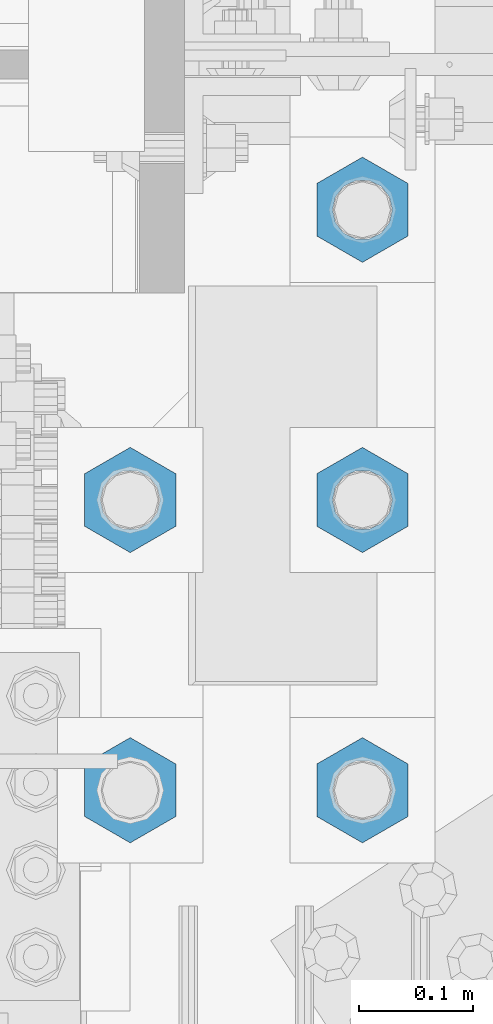
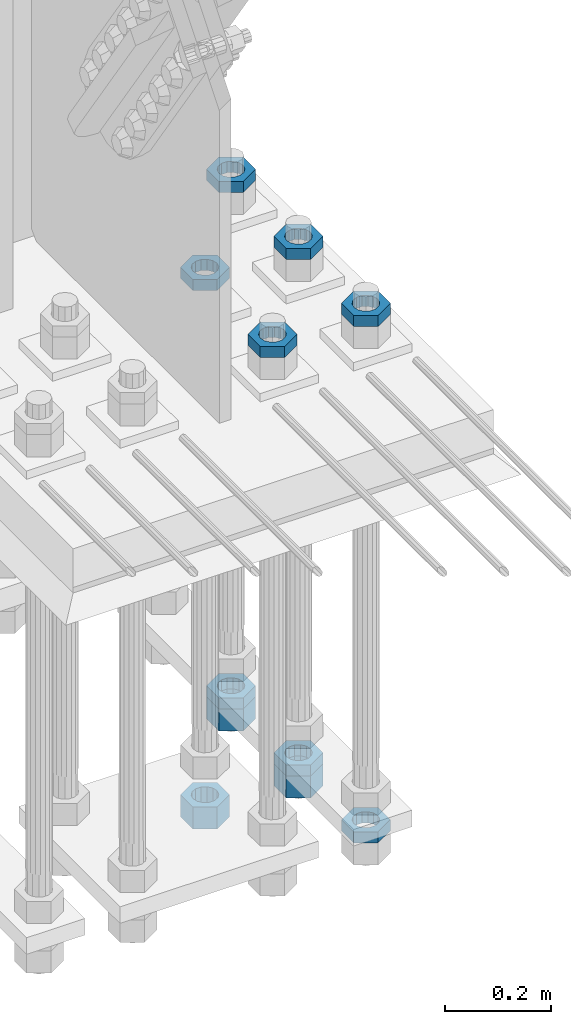
# One storey, part 2385 of 3843: 11 beams, 1 element without a shape of its own.
"""IFC2X3 building model written with IfcOpenShell, lengths in millimetres."""

from ifc_helpers import new_model, si_unit, frame, origin_with_axes, place, context, subcontext, project, spatial, faceted_brep, material, type_object, element, aggregate, save


model = new_model("IFC2X3")

# Units and contexts
model_context = context("Model", 3, precision=1e-05, world=origin_with_axes())
body_context = subcontext(model_context, "Body", "Model", "MODEL_VIEW")
ifc_project = project(units=[si_unit("LENGTHUNIT", "METRE", prefix="MILLI"), si_unit("AREAUNIT", "SQUARE_METRE"), si_unit("VOLUMEUNIT", "CUBIC_METRE"), si_unit("MASSUNIT", "GRAM", prefix="KILO"), si_unit("TIMEUNIT", "SECOND"), si_unit("PLANEANGLEUNIT", "RADIAN"), si_unit("SOLIDANGLEUNIT", "STERADIAN"), si_unit("THERMODYNAMICTEMPERATUREUNIT", "DEGREE_CELSIUS"), si_unit("LUMINOUSINTENSITYUNIT", "LUMEN")], contexts=[model_context])

# Site, building, storey
site_placement = place(None, origin_with_axes())
site = spatial("IfcSite", under=ifc_project, at=site_placement, CompositionType="ELEMENT")
building_placement = place(site_placement, origin_with_axes())
building = spatial("IfcBuilding", under=site, at=building_placement, Name="Undefined", CompositionType="ELEMENT")
storey_placement = place(building_placement, origin_with_axes())
storey = spatial("IfcBuildingStorey", under=building, at=storey_placement, Name="Undefined", CompositionType="ELEMENT", Elevation=0.0)

# Assembly, beams
assembly_placement = place(storey_placement, origin_with_axes())
assembly = element("IfcElementAssembly", 1, at=assembly_placement, inside=storey, Name="TEMPLATE", AssemblyPlace="NOTDEFINED", PredefinedType="RIGID_FRAME")
ifc_material = material(Name="STEEL/A572-50")
beam_type_1 = type_object("IfcBeamType", Name="2_HALF_NUT", PredefinedType="NOTDEFINED")
beam_1_placement = place(assembly_placement, frame((36931.6, 74993.5, 29070.3), z_axis=(1.0, 0.0, 0.0), x_axis=(0.0, 0.0, -1.0)))
beam_1 = element("IfcBeam", 2, at=beam_1_placement, type_object=beam_type_1, material=ifc_material, Name="NUT", ObjectType="2_HALF_NUT", context=body_context, shape_type="Brep", body=[
    faceted_brep([(0.0, -46.0369987487793, 0.0), (0.0, -23.0184993743896, -39.869213104248), (25.4000000000015, -23.0184993743896, -39.869213104248), (25.4000000000015, -46.0369987487793, 0.0), (0.0, 23.0184993743896, -39.869213104248), (25.4000000000015, 23.0184993743896, -39.869213104248), (0.0, 46.0369987487793, 0.0), (25.4000000000015, 46.0369987487793, 0.0), (0.0, 23.0184993743896, 39.869213104248), (25.4000000000015, 23.0184993743896, 39.869213104248), (0.0, -23.0184993743896, 39.869213104248), (25.4000000000015, -23.0184993743896, 39.869213104248), (0.0, 0.0, 26.1940002441406), (0.0, 11.3650617044477, 23.5999013092805), (25.4000000000015, 11.3650617044477, 23.5999013092805), (25.4000000000015, 0.0, 26.1940002441406), (0.0, 20.4791109456419, 16.3316083006721), (25.4000000000015, 20.4791109456419, 16.3316083006721), (0.0, 25.5370200498292, 5.82867859874386), (25.4000000000015, 25.5370200498292, 5.82867859874386), (0.0, 25.5370200498292, -5.82867859874386), (25.4000000000015, 25.5370200498292, -5.82867859874386), (0.0, 20.4791109456419, -16.3316083006721), (25.4000000000015, 20.4791109456419, -16.3316083006721), (0.0, 11.3650617044477, -23.5999013092805), (25.4000000000015, 11.3650617044477, -23.5999013092805), (0.0, 0.0, -26.1940002441406), (25.4000000000015, 0.0, -26.1940002441406), (0.0, -11.3650617044477, -23.5999013092805), (25.4000000000015, -11.3650617044477, -23.5999013092805), (0.0, -20.4791109456419, -16.3316083006721), (25.4000000000015, -20.4791109456419, -16.3316083006721), (0.0, -25.5370200498292, -5.82867859874386), (25.4000000000015, -25.5370200498292, -5.82867859874386), (0.0, -25.5370200498292, 5.82867859874386), (25.4000000000015, -25.5370200498292, 5.82867859874386), (0.0, -20.4791109456419, 16.3316083006721), (25.4000000000015, -20.4791109456419, 16.3316083006721), (0.0, -11.3650617044477, 23.5999013092805), (25.4000000000015, -11.3650617044477, 23.5999013092805)], [[[0, 1, 2, 3]], [[1, 4, 5, 2]], [[4, 6, 7, 5]], [[6, 8, 9, 7]], [[8, 10, 11, 9]], [[10, 0, 3, 11]], [[12, 13, 14, 15]], [[13, 16, 17, 14]], [[16, 18, 19, 17]], [[18, 20, 21, 19]], [[20, 22, 23, 21]], [[22, 24, 25, 23]], [[24, 26, 27, 25]], [[26, 28, 29, 27]], [[28, 30, 31, 29]], [[30, 32, 33, 31]], [[32, 34, 35, 33]], [[34, 36, 37, 35]], [[36, 38, 39, 37]], [[38, 12, 15, 39]], [[5, 7, 9, 11, 3, 2], [17, 19, 21, 23, 25, 27, 29, 31, 33, 35, 37, 39, 15, 14]], [[10, 8, 6, 4, 1, 0], [38, 36, 34, 32, 30, 28, 26, 24, 22, 20, 18, 16, 13, 12]]]),
])
beam_2_placement = place(assembly_placement, frame((36931.6, 75247.5, 29070.3), z_axis=(1.0, 0.0, 0.0), x_axis=(0.0, 0.0, -1.0)))
beam_2 = element("IfcBeam", 3, at=beam_2_placement, type_object=beam_type_1, material=ifc_material, Name="NUT", ObjectType="2_HALF_NUT", context=body_context, shape_type="Brep", body=[
    faceted_brep([(0.0, -46.0369987487793, 0.0), (0.0, -23.0184993743896, -39.869213104248), (25.4000000000015, -23.0184993743896, -39.869213104248), (25.4000000000015, -46.0369987487793, 0.0), (0.0, 23.0184993743896, -39.869213104248), (25.4000000000015, 23.0184993743896, -39.869213104248), (0.0, 46.0369987487793, 0.0), (25.4000000000015, 46.0369987487793, 0.0), (0.0, 23.0184993743896, 39.869213104248), (25.4000000000015, 23.0184993743896, 39.869213104248), (0.0, -23.0184993743896, 39.869213104248), (25.4000000000015, -23.0184993743896, 39.869213104248), (0.0, 0.0, 26.1940002441406), (0.0, 11.3650617044477, 23.5999013092805), (25.4000000000015, 11.3650617044477, 23.5999013092805), (25.4000000000015, 0.0, 26.1940002441406), (0.0, 20.4791109456419, 16.3316083006721), (25.4000000000015, 20.4791109456419, 16.3316083006721), (0.0, 25.5370200498292, 5.82867859874386), (25.4000000000015, 25.5370200498292, 5.82867859874386), (0.0, 25.5370200498292, -5.82867859874386), (25.4000000000015, 25.5370200498292, -5.82867859874386), (0.0, 20.4791109456419, -16.3316083006721), (25.4000000000015, 20.4791109456419, -16.3316083006721), (0.0, 11.3650617044477, -23.5999013092805), (25.4000000000015, 11.3650617044477, -23.5999013092805), (0.0, 0.0, -26.1940002441406), (25.4000000000015, 0.0, -26.1940002441406), (0.0, -11.3650617044477, -23.5999013092805), (25.4000000000015, -11.3650617044477, -23.5999013092805), (0.0, -20.4791109456419, -16.3316083006721), (25.4000000000015, -20.4791109456419, -16.3316083006721), (0.0, -25.5370200498292, -5.82867859874386), (25.4000000000015, -25.5370200498292, -5.82867859874386), (0.0, -25.5370200498292, 5.82867859874386), (25.4000000000015, -25.5370200498292, 5.82867859874386), (0.0, -20.4791109456419, 16.3316083006721), (25.4000000000015, -20.4791109456419, 16.3316083006721), (0.0, -11.3650617044477, 23.5999013092805), (25.4000000000015, -11.3650617044477, 23.5999013092805)], [[[0, 1, 2, 3]], [[1, 4, 5, 2]], [[4, 6, 7, 5]], [[6, 8, 9, 7]], [[8, 10, 11, 9]], [[10, 0, 3, 11]], [[12, 13, 14, 15]], [[13, 16, 17, 14]], [[16, 18, 19, 17]], [[18, 20, 21, 19]], [[20, 22, 23, 21]], [[22, 24, 25, 23]], [[24, 26, 27, 25]], [[26, 28, 29, 27]], [[28, 30, 31, 29]], [[30, 32, 33, 31]], [[32, 34, 35, 33]], [[34, 36, 37, 35]], [[36, 38, 39, 37]], [[38, 12, 15, 39]], [[5, 7, 9, 11, 3, 2], [17, 19, 21, 23, 25, 27, 29, 31, 33, 35, 37, 39, 15, 14]], [[10, 8, 6, 4, 1, 0], [38, 36, 34, 32, 30, 28, 26, 24, 22, 20, 18, 16, 13, 12]]]),
])
beam_3_placement = place(assembly_placement, frame((36931.6, 75501.5, 29070.3), z_axis=(-1.0, 0.0, 0.0), x_axis=(0.0, 0.0, -1.0)))
beam_3 = element("IfcBeam", 4, at=beam_3_placement, type_object=beam_type_1, material=ifc_material, Name="NUT", ObjectType="2_HALF_NUT", context=body_context, shape_type="Brep", body=[
    faceted_brep([(0.0, -46.0369987487793, 0.0), (0.0, -23.0184993743896, -39.869213104248), (25.4000000000015, -23.0184993743896, -39.869213104248), (25.4000000000015, -46.0369987487793, 0.0), (0.0, 23.0184993743896, -39.869213104248), (25.4000000000015, 23.0184993743896, -39.869213104248), (0.0, 46.0369987487793, 0.0), (25.4000000000015, 46.0369987487793, 0.0), (0.0, 23.0184993743896, 39.869213104248), (25.4000000000015, 23.0184993743896, 39.869213104248), (0.0, -23.0184993743896, 39.869213104248), (25.4000000000015, -23.0184993743896, 39.869213104248), (0.0, 0.0, 26.1940002441406), (0.0, 11.3650617044477, 23.5999013092805), (25.4000000000015, 11.3650617044477, 23.5999013092805), (25.4000000000015, 0.0, 26.1940002441406), (0.0, 20.4791109456419, 16.3316083006721), (25.4000000000015, 20.4791109456419, 16.3316083006721), (0.0, 25.5370200498292, 5.82867859874386), (25.4000000000015, 25.5370200498292, 5.82867859874386), (0.0, 25.5370200498292, -5.82867859874386), (25.4000000000015, 25.5370200498292, -5.82867859874386), (0.0, 20.4791109456419, -16.3316083006721), (25.4000000000015, 20.4791109456419, -16.3316083006721), (0.0, 11.3650617044477, -23.5999013092805), (25.4000000000015, 11.3650617044477, -23.5999013092805), (0.0, 0.0, -26.1940002441406), (25.4000000000015, 0.0, -26.1940002441406), (0.0, -11.3650617044477, -23.5999013092805), (25.4000000000015, -11.3650617044477, -23.5999013092805), (0.0, -20.4791109456419, -16.3316083006721), (25.4000000000015, -20.4791109456419, -16.3316083006721), (0.0, -25.5370200498292, -5.82867859874386), (25.4000000000015, -25.5370200498292, -5.82867859874386), (0.0, -25.5370200498292, 5.82867859874386), (25.4000000000015, -25.5370200498292, 5.82867859874386), (0.0, -20.4791109456419, 16.3316083006721), (25.4000000000015, -20.4791109456419, 16.3316083006721), (0.0, -11.3650617044477, 23.5999013092805), (25.4000000000015, -11.3650617044477, 23.5999013092805)], [[[0, 1, 2, 3]], [[1, 4, 5, 2]], [[4, 6, 7, 5]], [[6, 8, 9, 7]], [[8, 10, 11, 9]], [[10, 0, 3, 11]], [[12, 13, 14, 15]], [[13, 16, 17, 14]], [[16, 18, 19, 17]], [[18, 20, 21, 19]], [[20, 22, 23, 21]], [[22, 24, 25, 23]], [[24, 26, 27, 25]], [[26, 28, 29, 27]], [[28, 30, 31, 29]], [[30, 32, 33, 31]], [[32, 34, 35, 33]], [[34, 36, 37, 35]], [[36, 38, 39, 37]], [[38, 12, 15, 39]], [[5, 7, 9, 11, 3, 2], [17, 19, 21, 23, 25, 27, 29, 31, 33, 35, 37, 39, 15, 14]], [[10, 8, 6, 4, 1, 0], [38, 36, 34, 32, 30, 28, 26, 24, 22, 20, 18, 16, 13, 12]]]),
])
beam_4_placement = place(assembly_placement, frame((36728.4, 75247.5, 30257.75), z_axis=(-1.0, 0.0, 0.0), x_axis=(0.0, 0.0, -1.0)))
beam_4 = element("IfcBeam", 5, at=beam_4_placement, type_object=beam_type_1, material=ifc_material, Name="NUT", ObjectType="2_HALF_NUT", context=body_context, shape_type="Brep", body=[
    faceted_brep([(0.0, -46.0369987487793, 0.0), (0.0, -23.0184993743896, -39.869213104248), (25.4000000000015, -23.0184993743896, -39.869213104248), (25.4000000000015, -46.0369987487793, 0.0), (0.0, 23.0184993743896, -39.869213104248), (25.4000000000015, 23.0184993743896, -39.869213104248), (0.0, 46.0369987487793, 0.0), (25.4000000000015, 46.0369987487793, 0.0), (0.0, 23.0184993743896, 39.869213104248), (25.4000000000015, 23.0184993743896, 39.869213104248), (0.0, -23.0184993743896, 39.869213104248), (25.4000000000015, -23.0184993743896, 39.869213104248), (0.0, 0.0, 26.1940002441406), (0.0, 11.3650617044477, 23.5999013092805), (25.4000000000015, 11.3650617044477, 23.5999013092805), (25.4000000000015, 0.0, 26.1940002441406), (0.0, 20.4791109456419, 16.3316083006721), (25.4000000000015, 20.4791109456419, 16.3316083006721), (0.0, 25.5370200498292, 5.82867859874386), (25.4000000000015, 25.5370200498292, 5.82867859874386), (0.0, 25.5370200498292, -5.82867859874386), (25.4000000000015, 25.5370200498292, -5.82867859874386), (0.0, 20.4791109456419, -16.3316083006721), (25.4000000000015, 20.4791109456419, -16.3316083006721), (0.0, 11.3650617044477, -23.5999013092805), (25.4000000000015, 11.3650617044477, -23.5999013092805), (0.0, 0.0, -26.1940002441406), (25.4000000000015, 0.0, -26.1940002441406), (0.0, -11.3650617044477, -23.5999013092805), (25.4000000000015, -11.3650617044477, -23.5999013092805), (0.0, -20.4791109456419, -16.3316083006721), (25.4000000000015, -20.4791109456419, -16.3316083006721), (0.0, -25.5370200498292, -5.82867859874386), (25.4000000000015, -25.5370200498292, -5.82867859874386), (0.0, -25.5370200498292, 5.82867859874386), (25.4000000000015, -25.5370200498292, 5.82867859874386), (0.0, -20.4791109456419, 16.3316083006721), (25.4000000000015, -20.4791109456419, 16.3316083006721), (0.0, -11.3650617044477, 23.5999013092805), (25.4000000000015, -11.3650617044477, 23.5999013092805)], [[[0, 1, 2, 3]], [[1, 4, 5, 2]], [[4, 6, 7, 5]], [[6, 8, 9, 7]], [[8, 10, 11, 9]], [[10, 0, 3, 11]], [[12, 13, 14, 15]], [[13, 16, 17, 14]], [[16, 18, 19, 17]], [[18, 20, 21, 19]], [[20, 22, 23, 21]], [[22, 24, 25, 23]], [[24, 26, 27, 25]], [[26, 28, 29, 27]], [[28, 30, 31, 29]], [[30, 32, 33, 31]], [[32, 34, 35, 33]], [[34, 36, 37, 35]], [[36, 38, 39, 37]], [[38, 12, 15, 39]], [[5, 7, 9, 11, 3, 2], [17, 19, 21, 23, 25, 27, 29, 31, 33, 35, 37, 39, 15, 14]], [[10, 8, 6, 4, 1, 0], [38, 36, 34, 32, 30, 28, 26, 24, 22, 20, 18, 16, 13, 12]]]),
])
beam_5_placement = place(assembly_placement, frame((36728.4, 74993.5, 30257.75), z_axis=(-1.0, 0.0, 0.0), x_axis=(0.0, 0.0, -1.0)))
beam_5 = element("IfcBeam", 6, at=beam_5_placement, type_object=beam_type_1, material=ifc_material, Name="NUT", ObjectType="2_HALF_NUT", context=body_context, shape_type="Brep", body=[
    faceted_brep([(0.0, -46.0369987487793, 0.0), (0.0, -23.0184993743896, -39.869213104248), (25.4000000000015, -23.0184993743896, -39.869213104248), (25.4000000000015, -46.0369987487793, 0.0), (0.0, 23.0184993743896, -39.869213104248), (25.4000000000015, 23.0184993743896, -39.869213104248), (0.0, 46.0369987487793, 0.0), (25.4000000000015, 46.0369987487793, 0.0), (0.0, 23.0184993743896, 39.869213104248), (25.4000000000015, 23.0184993743896, 39.869213104248), (0.0, -23.0184993743896, 39.869213104248), (25.4000000000015, -23.0184993743896, 39.869213104248), (0.0, 0.0, 26.1940002441406), (0.0, 11.3650617044477, 23.5999013092805), (25.4000000000015, 11.3650617044477, 23.5999013092805), (25.4000000000015, 0.0, 26.1940002441406), (0.0, 20.4791109456419, 16.3316083006721), (25.4000000000015, 20.4791109456419, 16.3316083006721), (0.0, 25.5370200498292, 5.82867859874386), (25.4000000000015, 25.5370200498292, 5.82867859874386), (0.0, 25.5370200498292, -5.82867859874386), (25.4000000000015, 25.5370200498292, -5.82867859874386), (0.0, 20.4791109456419, -16.3316083006721), (25.4000000000015, 20.4791109456419, -16.3316083006721), (0.0, 11.3650617044477, -23.5999013092805), (25.4000000000015, 11.3650617044477, -23.5999013092805), (0.0, 0.0, -26.1940002441406), (25.4000000000015, 0.0, -26.1940002441406), (0.0, -11.3650617044477, -23.5999013092805), (25.4000000000015, -11.3650617044477, -23.5999013092805), (0.0, -20.4791109456419, -16.3316083006721), (25.4000000000015, -20.4791109456419, -16.3316083006721), (0.0, -25.5370200498292, -5.82867859874386), (25.4000000000015, -25.5370200498292, -5.82867859874386), (0.0, -25.5370200498292, 5.82867859874386), (25.4000000000015, -25.5370200498292, 5.82867859874386), (0.0, -20.4791109456419, 16.3316083006721), (25.4000000000015, -20.4791109456419, 16.3316083006721), (0.0, -11.3650617044477, 23.5999013092805), (25.4000000000015, -11.3650617044477, 23.5999013092805)], [[[0, 1, 2, 3]], [[1, 4, 5, 2]], [[4, 6, 7, 5]], [[6, 8, 9, 7]], [[8, 10, 11, 9]], [[10, 0, 3, 11]], [[12, 13, 14, 15]], [[13, 16, 17, 14]], [[16, 18, 19, 17]], [[18, 20, 21, 19]], [[20, 22, 23, 21]], [[22, 24, 25, 23]], [[24, 26, 27, 25]], [[26, 28, 29, 27]], [[28, 30, 31, 29]], [[30, 32, 33, 31]], [[32, 34, 35, 33]], [[34, 36, 37, 35]], [[36, 38, 39, 37]], [[38, 12, 15, 39]], [[5, 7, 9, 11, 3, 2], [17, 19, 21, 23, 25, 27, 29, 31, 33, 35, 37, 39, 15, 14]], [[10, 8, 6, 4, 1, 0], [38, 36, 34, 32, 30, 28, 26, 24, 22, 20, 18, 16, 13, 12]]]),
])
beam_6_placement = place(assembly_placement, frame((36931.6, 75501.5, 30257.75), z_axis=(1.0, 0.0, 0.0), x_axis=(0.0, 0.0, -1.0)))
beam_6 = element("IfcBeam", 7, at=beam_6_placement, type_object=beam_type_1, material=ifc_material, Name="NUT", ObjectType="2_HALF_NUT", context=body_context, shape_type="Brep", body=[
    faceted_brep([(0.0, -46.0369987487793, 0.0), (0.0, -23.0184993743896, -39.869213104248), (25.4000000000015, -23.0184993743896, -39.869213104248), (25.4000000000015, -46.0369987487793, 0.0), (0.0, 23.0184993743896, -39.869213104248), (25.4000000000015, 23.0184993743896, -39.869213104248), (0.0, 46.0369987487793, 0.0), (25.4000000000015, 46.0369987487793, 0.0), (0.0, 23.0184993743896, 39.869213104248), (25.4000000000015, 23.0184993743896, 39.869213104248), (0.0, -23.0184993743896, 39.869213104248), (25.4000000000015, -23.0184993743896, 39.869213104248), (0.0, 0.0, 26.1940002441406), (0.0, 11.3650617044477, 23.5999013092805), (25.4000000000015, 11.3650617044477, 23.5999013092805), (25.4000000000015, 0.0, 26.1940002441406), (0.0, 20.4791109456419, 16.3316083006721), (25.4000000000015, 20.4791109456419, 16.3316083006721), (0.0, 25.5370200498292, 5.82867859874386), (25.4000000000015, 25.5370200498292, 5.82867859874386), (0.0, 25.5370200498292, -5.82867859874386), (25.4000000000015, 25.5370200498292, -5.82867859874386), (0.0, 20.4791109456419, -16.3316083006721), (25.4000000000015, 20.4791109456419, -16.3316083006721), (0.0, 11.3650617044477, -23.5999013092805), (25.4000000000015, 11.3650617044477, -23.5999013092805), (0.0, 0.0, -26.1940002441406), (25.4000000000015, 0.0, -26.1940002441406), (0.0, -11.3650617044477, -23.5999013092805), (25.4000000000015, -11.3650617044477, -23.5999013092805), (0.0, -20.4791109456419, -16.3316083006721), (25.4000000000015, -20.4791109456419, -16.3316083006721), (0.0, -25.5370200498292, -5.82867859874386), (25.4000000000015, -25.5370200498292, -5.82867859874386), (0.0, -25.5370200498292, 5.82867859874386), (25.4000000000015, -25.5370200498292, 5.82867859874386), (0.0, -20.4791109456419, 16.3316083006721), (25.4000000000015, -20.4791109456419, 16.3316083006721), (0.0, -11.3650617044477, 23.5999013092805), (25.4000000000015, -11.3650617044477, 23.5999013092805)], [[[0, 1, 2, 3]], [[1, 4, 5, 2]], [[4, 6, 7, 5]], [[6, 8, 9, 7]], [[8, 10, 11, 9]], [[10, 0, 3, 11]], [[12, 13, 14, 15]], [[13, 16, 17, 14]], [[16, 18, 19, 17]], [[18, 20, 21, 19]], [[20, 22, 23, 21]], [[22, 24, 25, 23]], [[24, 26, 27, 25]], [[26, 28, 29, 27]], [[28, 30, 31, 29]], [[30, 32, 33, 31]], [[32, 34, 35, 33]], [[34, 36, 37, 35]], [[36, 38, 39, 37]], [[38, 12, 15, 39]], [[5, 7, 9, 11, 3, 2], [17, 19, 21, 23, 25, 27, 29, 31, 33, 35, 37, 39, 15, 14]], [[10, 8, 6, 4, 1, 0], [38, 36, 34, 32, 30, 28, 26, 24, 22, 20, 18, 16, 13, 12]]]),
])
beam_7_placement = place(assembly_placement, frame((36931.6, 75247.5, 30257.75), z_axis=(-1.0, 0.0, 0.0), x_axis=(0.0, 0.0, -1.0)))
beam_7 = element("IfcBeam", 8, at=beam_7_placement, type_object=beam_type_1, material=ifc_material, Name="NUT", ObjectType="2_HALF_NUT", context=body_context, shape_type="Brep", body=[
    faceted_brep([(0.0, -46.0369987487793, 0.0), (0.0, -23.0184993743896, -39.869213104248), (25.4000000000015, -23.0184993743896, -39.869213104248), (25.4000000000015, -46.0369987487793, 0.0), (0.0, 23.0184993743896, -39.869213104248), (25.4000000000015, 23.0184993743896, -39.869213104248), (0.0, 46.0369987487793, 0.0), (25.4000000000015, 46.0369987487793, 0.0), (0.0, 23.0184993743896, 39.869213104248), (25.4000000000015, 23.0184993743896, 39.869213104248), (0.0, -23.0184993743896, 39.869213104248), (25.4000000000015, -23.0184993743896, 39.869213104248), (0.0, 0.0, 26.1940002441406), (0.0, 11.3650617044477, 23.5999013092805), (25.4000000000015, 11.3650617044477, 23.5999013092805), (25.4000000000015, 0.0, 26.1940002441406), (0.0, 20.4791109456419, 16.3316083006721), (25.4000000000015, 20.4791109456419, 16.3316083006721), (0.0, 25.5370200498292, 5.82867859874386), (25.4000000000015, 25.5370200498292, 5.82867859874386), (0.0, 25.5370200498292, -5.82867859874386), (25.4000000000015, 25.5370200498292, -5.82867859874386), (0.0, 20.4791109456419, -16.3316083006721), (25.4000000000015, 20.4791109456419, -16.3316083006721), (0.0, 11.3650617044477, -23.5999013092805), (25.4000000000015, 11.3650617044477, -23.5999013092805), (0.0, 0.0, -26.1940002441406), (25.4000000000015, 0.0, -26.1940002441406), (0.0, -11.3650617044477, -23.5999013092805), (25.4000000000015, -11.3650617044477, -23.5999013092805), (0.0, -20.4791109456419, -16.3316083006721), (25.4000000000015, -20.4791109456419, -16.3316083006721), (0.0, -25.5370200498292, -5.82867859874386), (25.4000000000015, -25.5370200498292, -5.82867859874386), (0.0, -25.5370200498292, 5.82867859874386), (25.4000000000015, -25.5370200498292, 5.82867859874386), (0.0, -20.4791109456419, 16.3316083006721), (25.4000000000015, -20.4791109456419, 16.3316083006721), (0.0, -11.3650617044477, 23.5999013092805), (25.4000000000015, -11.3650617044477, 23.5999013092805)], [[[0, 1, 2, 3]], [[1, 4, 5, 2]], [[4, 6, 7, 5]], [[6, 8, 9, 7]], [[8, 10, 11, 9]], [[10, 0, 3, 11]], [[12, 13, 14, 15]], [[13, 16, 17, 14]], [[16, 18, 19, 17]], [[18, 20, 21, 19]], [[20, 22, 23, 21]], [[22, 24, 25, 23]], [[24, 26, 27, 25]], [[26, 28, 29, 27]], [[28, 30, 31, 29]], [[30, 32, 33, 31]], [[32, 34, 35, 33]], [[34, 36, 37, 35]], [[36, 38, 39, 37]], [[38, 12, 15, 39]], [[5, 7, 9, 11, 3, 2], [17, 19, 21, 23, 25, 27, 29, 31, 33, 35, 37, 39, 15, 14]], [[10, 8, 6, 4, 1, 0], [38, 36, 34, 32, 30, 28, 26, 24, 22, 20, 18, 16, 13, 12]]]),
])
beam_8_placement = place(assembly_placement, frame((36931.6, 74993.5, 30257.75), z_axis=(-1.0, 0.0, 0.0), x_axis=(0.0, 0.0, -1.0)))
beam_8 = element("IfcBeam", 9, at=beam_8_placement, type_object=beam_type_1, material=ifc_material, Name="NUT", ObjectType="2_HALF_NUT", context=body_context, shape_type="Brep", body=[
    faceted_brep([(0.0, -46.0369987487793, 0.0), (0.0, -23.0184993743896, -39.869213104248), (25.4000000000015, -23.0184993743896, -39.869213104248), (25.4000000000015, -46.0369987487793, 0.0), (0.0, 23.0184993743896, -39.869213104248), (25.4000000000015, 23.0184993743896, -39.869213104248), (0.0, 46.0369987487793, 0.0), (25.4000000000015, 46.0369987487793, 0.0), (0.0, 23.0184993743896, 39.869213104248), (25.4000000000015, 23.0184993743896, 39.869213104248), (0.0, -23.0184993743896, 39.869213104248), (25.4000000000015, -23.0184993743896, 39.869213104248), (0.0, 0.0, 26.1940002441406), (0.0, 11.3650617044477, 23.5999013092805), (25.4000000000015, 11.3650617044477, 23.5999013092805), (25.4000000000015, 0.0, 26.1940002441406), (0.0, 20.4791109456419, 16.3316083006721), (25.4000000000015, 20.4791109456419, 16.3316083006721), (0.0, 25.5370200498292, 5.82867859874386), (25.4000000000015, 25.5370200498292, 5.82867859874386), (0.0, 25.5370200498292, -5.82867859874386), (25.4000000000015, 25.5370200498292, -5.82867859874386), (0.0, 20.4791109456419, -16.3316083006721), (25.4000000000015, 20.4791109456419, -16.3316083006721), (0.0, 11.3650617044477, -23.5999013092805), (25.4000000000015, 11.3650617044477, -23.5999013092805), (0.0, 0.0, -26.1940002441406), (25.4000000000015, 0.0, -26.1940002441406), (0.0, -11.3650617044477, -23.5999013092805), (25.4000000000015, -11.3650617044477, -23.5999013092805), (0.0, -20.4791109456419, -16.3316083006721), (25.4000000000015, -20.4791109456419, -16.3316083006721), (0.0, -25.5370200498292, -5.82867859874386), (25.4000000000015, -25.5370200498292, -5.82867859874386), (0.0, -25.5370200498292, 5.82867859874386), (25.4000000000015, -25.5370200498292, 5.82867859874386), (0.0, -20.4791109456419, 16.3316083006721), (25.4000000000015, -20.4791109456419, 16.3316083006721), (0.0, -11.3650617044477, 23.5999013092805), (25.4000000000015, -11.3650617044477, 23.5999013092805)], [[[0, 1, 2, 3]], [[1, 4, 5, 2]], [[4, 6, 7, 5]], [[6, 8, 9, 7]], [[8, 10, 11, 9]], [[10, 0, 3, 11]], [[12, 13, 14, 15]], [[13, 16, 17, 14]], [[16, 18, 19, 17]], [[18, 20, 21, 19]], [[20, 22, 23, 21]], [[22, 24, 25, 23]], [[24, 26, 27, 25]], [[26, 28, 29, 27]], [[28, 30, 31, 29]], [[30, 32, 33, 31]], [[32, 34, 35, 33]], [[34, 36, 37, 35]], [[36, 38, 39, 37]], [[38, 12, 15, 39]], [[5, 7, 9, 11, 3, 2], [17, 19, 21, 23, 25, 27, 29, 31, 33, 35, 37, 39, 15, 14]], [[10, 8, 6, 4, 1, 0], [38, 36, 34, 32, 30, 28, 26, 24, 22, 20, 18, 16, 13, 12]]]),
])
beam_type_2 = type_object("IfcBeamType", Name="2_HEAVY_HEX_NUT", PredefinedType="NOTDEFINED")
beam_9_placement = place(assembly_placement, frame((36931.6, 75247.5, 29044.9), z_axis=(1.0, 0.0, 0.0), x_axis=(0.0, 0.0, -1.0)))
beam_9 = element("IfcBeam", 10, at=beam_9_placement, type_object=beam_type_2, material=ifc_material, Name="NUT", ObjectType="2_HEAVY_HEX_NUT", context=body_context, shape_type="Brep", body=[
    faceted_brep([(0.0, -46.0369987487793, 0.0), (0.0, -23.0184993743896, -39.869213104248), (50.7999999999993, -23.0184993743896, -39.869213104248), (50.7999999999993, -46.0369987487793, 0.0), (0.0, 23.0184993743896, -39.869213104248), (50.7999999999993, 23.0184993743896, -39.869213104248), (0.0, 46.0369987487793, 0.0), (50.7999999999993, 46.0369987487793, 0.0), (0.0, 23.0184993743896, 39.869213104248), (50.7999999999993, 23.0184993743896, 39.869213104248), (0.0, -23.0184993743896, 39.869213104248), (50.7999999999993, -23.0184993743896, 39.869213104248), (0.0, 0.0, 26.1940002441406), (0.0, 11.3650617044477, 23.5999013092805), (50.7999999999993, 11.3650617044477, 23.5999013092805), (50.7999999999993, 0.0, 26.1940002441406), (0.0, 20.4791109456419, 16.3316083006721), (50.7999999999993, 20.4791109456419, 16.3316083006721), (0.0, 25.5370200498292, 5.82867859874386), (50.7999999999993, 25.5370200498292, 5.82867859874386), (0.0, 25.5370200498292, -5.82867859874386), (50.7999999999993, 25.5370200498292, -5.82867859874386), (0.0, 20.4791109456419, -16.3316083006721), (50.7999999999993, 20.4791109456419, -16.3316083006721), (0.0, 11.3650617044477, -23.5999013092805), (50.7999999999993, 11.3650617044477, -23.5999013092805), (0.0, 0.0, -26.1940002441406), (50.7999999999993, 0.0, -26.1940002441406), (0.0, -11.3650617044477, -23.5999013092805), (50.7999999999993, -11.3650617044477, -23.5999013092805), (0.0, -20.4791109456419, -16.3316083006721), (50.7999999999993, -20.4791109456419, -16.3316083006721), (0.0, -25.5370200498292, -5.82867859874386), (50.7999999999993, -25.5370200498292, -5.82867859874386), (0.0, -25.5370200498292, 5.82867859874386), (50.7999999999993, -25.5370200498292, 5.82867859874386), (0.0, -20.4791109456419, 16.3316083006721), (50.7999999999993, -20.4791109456419, 16.3316083006721), (0.0, -11.3650617044477, 23.5999013092805), (50.7999999999993, -11.3650617044477, 23.5999013092805)], [[[0, 1, 2, 3]], [[1, 4, 5, 2]], [[4, 6, 7, 5]], [[6, 8, 9, 7]], [[8, 10, 11, 9]], [[10, 0, 3, 11]], [[12, 13, 14, 15]], [[13, 16, 17, 14]], [[16, 18, 19, 17]], [[18, 20, 21, 19]], [[20, 22, 23, 21]], [[22, 24, 25, 23]], [[24, 26, 27, 25]], [[26, 28, 29, 27]], [[28, 30, 31, 29]], [[30, 32, 33, 31]], [[32, 34, 35, 33]], [[34, 36, 37, 35]], [[36, 38, 39, 37]], [[38, 12, 15, 39]], [[5, 7, 9, 11, 3, 2], [17, 19, 21, 23, 25, 27, 29, 31, 33, 35, 37, 39, 15, 14]], [[10, 8, 6, 4, 1, 0], [38, 36, 34, 32, 30, 28, 26, 24, 22, 20, 18, 16, 13, 12]]]),
])
beam_10_placement = place(assembly_placement, frame((36931.6, 75501.5, 29044.9), z_axis=(-1.0, 0.0, 0.0), x_axis=(0.0, 0.0, -1.0)))
beam_10 = element("IfcBeam", 11, at=beam_10_placement, type_object=beam_type_2, material=ifc_material, Name="NUT", ObjectType="2_HEAVY_HEX_NUT", context=body_context, shape_type="Brep", body=[
    faceted_brep([(0.0, -46.0369987487793, 0.0), (0.0, -23.0184993743896, -39.869213104248), (50.7999999999993, -23.0184993743896, -39.869213104248), (50.7999999999993, -46.0369987487793, 0.0), (0.0, 23.0184993743896, -39.869213104248), (50.7999999999993, 23.0184993743896, -39.869213104248), (0.0, 46.0369987487793, 0.0), (50.7999999999993, 46.0369987487793, 0.0), (0.0, 23.0184993743896, 39.869213104248), (50.7999999999993, 23.0184993743896, 39.869213104248), (0.0, -23.0184993743896, 39.869213104248), (50.7999999999993, -23.0184993743896, 39.869213104248), (0.0, 0.0, 26.1940002441406), (0.0, 11.3650617044477, 23.5999013092805), (50.7999999999993, 11.3650617044477, 23.5999013092805), (50.7999999999993, 0.0, 26.1940002441406), (0.0, 20.4791109456419, 16.3316083006721), (50.7999999999993, 20.4791109456419, 16.3316083006721), (0.0, 25.5370200498292, 5.82867859874386), (50.7999999999993, 25.5370200498292, 5.82867859874386), (0.0, 25.5370200498292, -5.82867859874386), (50.7999999999993, 25.5370200498292, -5.82867859874386), (0.0, 20.4791109456419, -16.3316083006721), (50.7999999999993, 20.4791109456419, -16.3316083006721), (0.0, 11.3650617044477, -23.5999013092805), (50.7999999999993, 11.3650617044477, -23.5999013092805), (0.0, 0.0, -26.1940002441406), (50.7999999999993, 0.0, -26.1940002441406), (0.0, -11.3650617044477, -23.5999013092805), (50.7999999999993, -11.3650617044477, -23.5999013092805), (0.0, -20.4791109456419, -16.3316083006721), (50.7999999999993, -20.4791109456419, -16.3316083006721), (0.0, -25.5370200498292, -5.82867859874386), (50.7999999999993, -25.5370200498292, -5.82867859874386), (0.0, -25.5370200498292, 5.82867859874386), (50.7999999999993, -25.5370200498292, 5.82867859874386), (0.0, -20.4791109456419, 16.3316083006721), (50.7999999999993, -20.4791109456419, 16.3316083006721), (0.0, -11.3650617044477, 23.5999013092805), (50.7999999999993, -11.3650617044477, 23.5999013092805)], [[[0, 1, 2, 3]], [[1, 4, 5, 2]], [[4, 6, 7, 5]], [[6, 8, 9, 7]], [[8, 10, 11, 9]], [[10, 0, 3, 11]], [[12, 13, 14, 15]], [[13, 16, 17, 14]], [[16, 18, 19, 17]], [[18, 20, 21, 19]], [[20, 22, 23, 21]], [[22, 24, 25, 23]], [[24, 26, 27, 25]], [[26, 28, 29, 27]], [[28, 30, 31, 29]], [[30, 32, 33, 31]], [[32, 34, 35, 33]], [[34, 36, 37, 35]], [[36, 38, 39, 37]], [[38, 12, 15, 39]], [[5, 7, 9, 11, 3, 2], [17, 19, 21, 23, 25, 27, 29, 31, 33, 35, 37, 39, 15, 14]], [[10, 8, 6, 4, 1, 0], [38, 36, 34, 32, 30, 28, 26, 24, 22, 20, 18, 16, 13, 12]]]),
])
beam_11_placement = place(assembly_placement, frame((36728.4, 75247.5, 29044.9), z_axis=(-1.0, 0.0, 0.0), x_axis=(0.0, 0.0, -1.0)))
beam_11 = element("IfcBeam", 12, at=beam_11_placement, type_object=beam_type_2, material=ifc_material, Name="NUT", ObjectType="2_HEAVY_HEX_NUT", context=body_context, shape_type="Brep", body=[
    faceted_brep([(0.0, -46.0369987487793, 0.0), (0.0, -23.0184993743896, -39.869213104248), (50.7999999999993, -23.0184993743896, -39.869213104248), (50.7999999999993, -46.0369987487793, 0.0), (0.0, 23.0184993743896, -39.869213104248), (50.7999999999993, 23.0184993743896, -39.869213104248), (0.0, 46.0369987487793, 0.0), (50.7999999999993, 46.0369987487793, 0.0), (0.0, 23.0184993743896, 39.869213104248), (50.7999999999993, 23.0184993743896, 39.869213104248), (0.0, -23.0184993743896, 39.869213104248), (50.7999999999993, -23.0184993743896, 39.869213104248), (0.0, 0.0, 26.1940002441406), (0.0, 11.3650617044477, 23.5999013092805), (50.7999999999993, 11.3650617044477, 23.5999013092805), (50.7999999999993, 0.0, 26.1940002441406), (0.0, 20.4791109456419, 16.3316083006721), (50.7999999999993, 20.4791109456419, 16.3316083006721), (0.0, 25.5370200498292, 5.82867859874386), (50.7999999999993, 25.5370200498292, 5.82867859874386), (0.0, 25.5370200498292, -5.82867859874386), (50.7999999999993, 25.5370200498292, -5.82867859874386), (0.0, 20.4791109456419, -16.3316083006721), (50.7999999999993, 20.4791109456419, -16.3316083006721), (0.0, 11.3650617044477, -23.5999013092805), (50.7999999999993, 11.3650617044477, -23.5999013092805), (0.0, 0.0, -26.1940002441406), (50.7999999999993, 0.0, -26.1940002441406), (0.0, -11.3650617044477, -23.5999013092805), (50.7999999999993, -11.3650617044477, -23.5999013092805), (0.0, -20.4791109456419, -16.3316083006721), (50.7999999999993, -20.4791109456419, -16.3316083006721), (0.0, -25.5370200498292, -5.82867859874386), (50.7999999999993, -25.5370200498292, -5.82867859874386), (0.0, -25.5370200498292, 5.82867859874386), (50.7999999999993, -25.5370200498292, 5.82867859874386), (0.0, -20.4791109456419, 16.3316083006721), (50.7999999999993, -20.4791109456419, 16.3316083006721), (0.0, -11.3650617044477, 23.5999013092805), (50.7999999999993, -11.3650617044477, 23.5999013092805)], [[[0, 1, 2, 3]], [[1, 4, 5, 2]], [[4, 6, 7, 5]], [[6, 8, 9, 7]], [[8, 10, 11, 9]], [[10, 0, 3, 11]], [[12, 13, 14, 15]], [[13, 16, 17, 14]], [[16, 18, 19, 17]], [[18, 20, 21, 19]], [[20, 22, 23, 21]], [[22, 24, 25, 23]], [[24, 26, 27, 25]], [[26, 28, 29, 27]], [[28, 30, 31, 29]], [[30, 32, 33, 31]], [[32, 34, 35, 33]], [[34, 36, 37, 35]], [[36, 38, 39, 37]], [[38, 12, 15, 39]], [[5, 7, 9, 11, 3, 2], [17, 19, 21, 23, 25, 27, 29, 31, 33, 35, 37, 39, 15, 14]], [[10, 8, 6, 4, 1, 0], [38, 36, 34, 32, 30, 28, 26, 24, 22, 20, 18, 16, 13, 12]]]),
])
aggregate(assembly, [beam_9, beam_10, beam_1, beam_2, beam_3, beam_4, beam_5, beam_6, beam_7, beam_8, beam_11])

save(model, "model.ifc")
